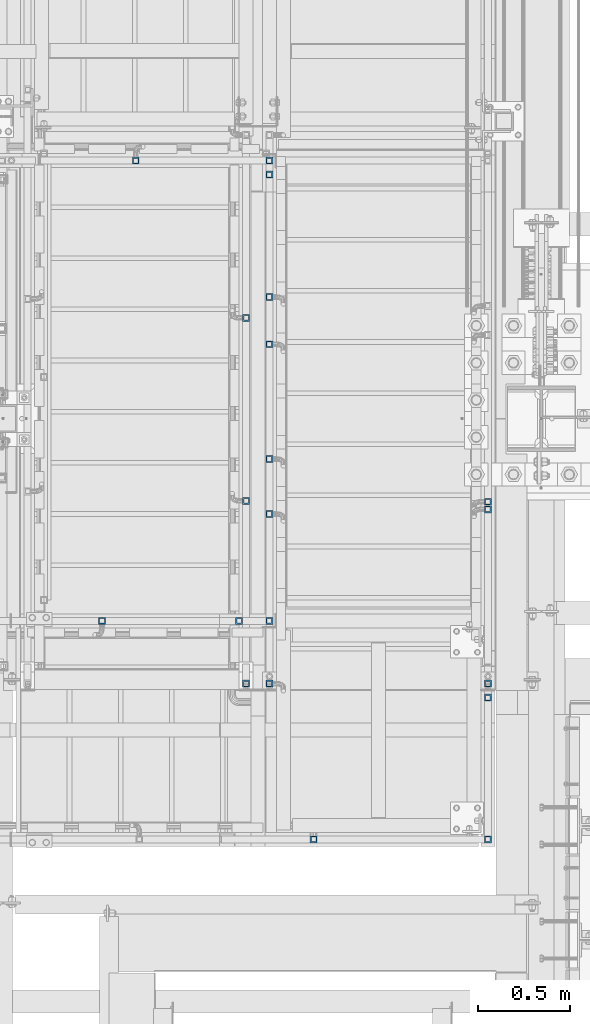
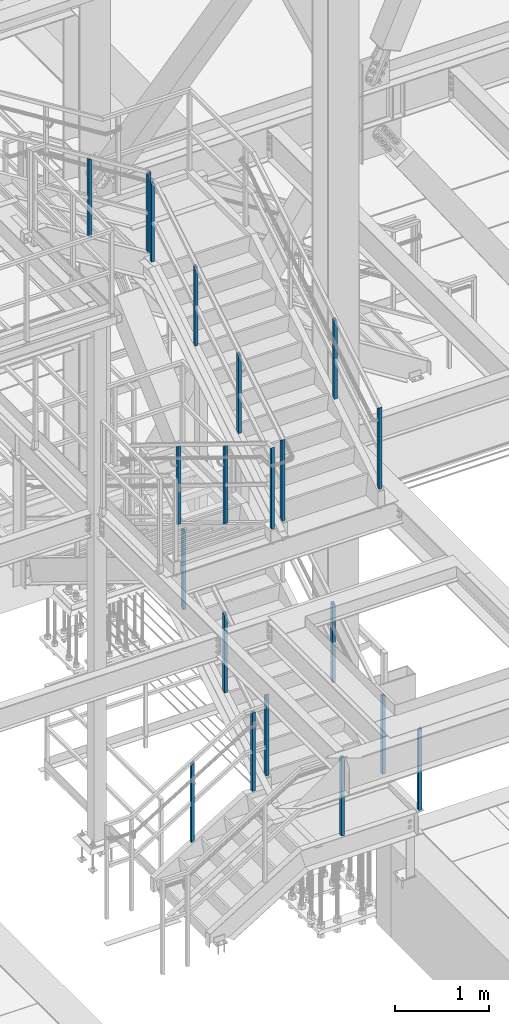
# One storey, part 1294 of 3843: 20 columns, 8 elements without a shape of their own.
"""IFC2X3 building model written with IfcOpenShell, lengths in millimetres."""

from ifc_helpers import new_model, si_unit, frame, origin_with_axes, place, context, subcontext, project, spatial, faceted_brep, material, type_object, element, aggregate, save


model = new_model("IFC2X3")

# Units and contexts
model_context = context("Model", 3, precision=1e-05, world=origin_with_axes())
body_context = subcontext(model_context, "Body", "Model", "MODEL_VIEW")
ifc_project = project(units=[si_unit("LENGTHUNIT", "METRE", prefix="MILLI"), si_unit("AREAUNIT", "SQUARE_METRE"), si_unit("VOLUMEUNIT", "CUBIC_METRE"), si_unit("MASSUNIT", "GRAM", prefix="KILO"), si_unit("TIMEUNIT", "SECOND"), si_unit("PLANEANGLEUNIT", "RADIAN"), si_unit("SOLIDANGLEUNIT", "STERADIAN"), si_unit("THERMODYNAMICTEMPERATUREUNIT", "DEGREE_CELSIUS"), si_unit("LUMINOUSINTENSITYUNIT", "LUMEN")], contexts=[model_context])

# Site, building, storey
site_placement = place(None, origin_with_axes())
site = spatial("IfcSite", under=ifc_project, at=site_placement, CompositionType="ELEMENT")
building_placement = place(site_placement, origin_with_axes())
building = spatial("IfcBuilding", under=site, at=building_placement, Name="Undefined", CompositionType="ELEMENT")
storey_placement = place(building_placement, origin_with_axes())
storey = spatial("IfcBuildingStorey", under=building, at=storey_placement, Name="Undefined", CompositionType="ELEMENT", Elevation=0.0)

# Assembly, columns
assembly_1_placement = place(storey_placement, origin_with_axes())
assembly_1 = element("IfcElementAssembly", 1, at=assembly_1_placement, inside=storey, Name="RAIL", AssemblyPlace="NOTDEFINED", PredefinedType="RIGID_FRAME")
ifc_material = material()
column_type = type_object("IfcColumnType", Name="HSS1-1/2X1-1/2X1/4", PredefinedType="NOTDEFINED")
column_1_placement = place(assembly_1_placement, frame((53714.6499999677, 21717.0000000151, 37251.6799666844), z_axis=(1.0, 0.0, 0.0), x_axis=(0.0, 0.0, 1.0)))
column_1 = element("IfcColumn", 2, at=column_1_placement, type_object=column_type, material=ifc_material, Name="POST", ObjectType="HSS1-1/2X1-1/2X1/4", context=body_context, shape_type="Brep", body=[
    faceted_brep([(-11.8918177007654, -19.0499992350015, 19.0499992350015), (11.8918177042287, -19.0499992350015, -19.0499992350015), (1026.29209956247, -19.0499999999993, -19.0499992350015), (1002.50846415752, -19.0499992350015, 19.0499992350015), (-11.8918177007654, 19.0499992350015, 19.0499992350015), (1002.50846415752, 19.0499992350015, 19.0499992350015), (11.8918177042287, 19.0499992350015, -19.0499992350015), (1026.29209956247, 19.0499992350015, -19.0499992350015), (-7.92787836672505, 12.6999993300014, 12.6999993299978), (-7.92787836672505, -12.6999993300014, 12.6999993299978), (7.92787837018841, -12.6999993300014, -12.6999993299978), (7.92787837018841, 12.6999993300014, -12.6999993299978), (1022.32816022843, 12.6999993300014, -12.6999993299978), (1006.47240349156, 12.6999993300014, 12.6999993299978), (1006.47240349156, -12.6999993300014, 12.6999993299978), (1022.32816022843, -12.6999993300014, -12.6999993299978)], [[[0, 1, 2, 3]], [[4, 0, 3, 5]], [[6, 4, 5, 7]], [[1, 0, 4, 6], [8, 9, 10, 11]], [[8, 11, 12, 13]], [[9, 8, 13, 14]], [[10, 9, 14, 15]], [[11, 10, 15, 12]], [[2, 7, 5, 3], [15, 14, 13, 12]], [[1, 6, 7, 2]]]),
])
column_2_placement = place(assembly_1_placement, frame((54444.900000001, 21717.0000000151, 36795.8269364284), z_axis=(1.0, 0.0, 0.0), x_axis=(0.0, 0.0, 1.0)))
column_2 = element("IfcColumn", 3, at=column_2_placement, type_object=column_type, material=ifc_material, Name="POST", ObjectType="HSS1-1/2X1-1/2X1/4", context=body_context, shape_type="Brep", body=[
    faceted_brep([(7.92787837018841, 12.6999993300014, -12.6999993299978), (7.92787837018841, -12.6999993300014, -12.6999993299978), (1029.81383504171, -12.6999993300014, -12.6999993299978), (1029.81383504171, 12.6999993300014, -12.6999993299978), (-7.92787836672505, -12.6999993300014, 12.6999993299978), (1043.90077281564, -12.6999993300014, 12.6999993299978), (-7.92787836672505, 12.6999993300014, 12.6999993299978), (1043.90077281564, 12.6999993300014, 12.6999993299978), (11.8918177042287, 19.0499992350015, -19.0499992350015), (-11.8918177007654, 19.0499992350015, 19.0499992350015), (1047.42250739222, 19.0499992350015, 19.0499992350015), (1026.29209956247, 19.0499992350015, -19.0499992350015), (-11.8918177007654, -19.0499992350015, 19.0499992350015), (1047.42250739222, -19.0499992350015, 19.0499992350015), (11.8918177042287, -19.0499992350015, -19.0499992350015), (1026.29209956247, -19.0499999999993, -19.0499992350015)], [[[0, 1, 2, 3]], [[1, 4, 5, 2]], [[4, 6, 7, 5]], [[6, 0, 3, 7]], [[8, 9, 10, 11]], [[9, 12, 13, 10]], [[12, 14, 15, 13]], [[14, 8, 11, 15]], [[13, 15, 11, 10], [5, 7, 3, 2]], [[14, 12, 9, 8], [6, 4, 1, 0]]]),
])
aggregate(assembly_1, [column_1, column_2])

assembly_2_placement = place(storey_placement, origin_with_axes())
assembly_2 = element("IfcElementAssembly", 4, at=assembly_2_placement, inside=storey, Name="RAIL", AssemblyPlace="NOTDEFINED", PredefinedType="RIGID_FRAME")
column_3_placement = place(assembly_2_placement, frame((54444.9, 21640.8000000047, 36694.533331298), z_axis=(0.0, -1.0, 0.0), x_axis=(0.0, 0.0, 1.0)))
column_3 = element("IfcColumn", 5, at=column_3_placement, type_object=column_type, material=ifc_material, Name="POST", ObjectType="HSS1-1/2X1-1/2X1/4", context=body_context, shape_type="Brep", body=[
    faceted_brep([(1079.49999933128, -12.6999993300014, -12.6999993299978), (1079.49999933128, 12.6999993300014, -12.6999993299978), (25.4000000135893, 12.6999993300014, -12.6999993299978), (25.4000000135893, -12.6999993300014, -12.6999993299978), (1054.10000067129, -12.6999993300014, 12.6999993299978), (25.4000000135893, -12.6999993300014, 12.6999993299978), (1054.10000067129, 12.6999993300014, 12.6999993299978), (25.4000000135893, 12.6999993300014, 12.6999993299978), (1047.75000076629, 19.0499992350015, 19.0499992349942), (1085.84999923629, 19.0499992350015, -19.0499992349942), (25.4000000135893, 19.0499992350015, -19.0499992349942), (25.4000000135893, 19.0499992350015, 19.0499992349942), (1047.75000076629, -19.0499992350015, 19.0499992349942), (25.4000000135893, -19.0499992350015, 19.0499992349942), (1085.84999923629, -19.0499992350015, -19.0499992349942), (25.4000000135893, -19.0499992350015, -19.0499992349942)], [[[0, 1, 2, 3]], [[4, 0, 3, 5]], [[6, 4, 5, 7]], [[1, 6, 7, 2]], [[8, 9, 10, 11]], [[12, 8, 11, 13]], [[14, 12, 13, 15]], [[9, 14, 15, 10]], [[12, 14, 9, 8], [4, 6, 1, 0]], [[10, 15, 13, 11], [2, 7, 5, 3]]]),
])
column_4_placement = place(assembly_2_placement, frame((54444.9, 20713.7000000044, 36201.2360274213), z_axis=(0.0, -1.0, 0.0), x_axis=(0.0, 0.0, 1.0)))
column_4 = element("IfcColumn", 6, at=column_4_placement, type_object=column_type, material=ifc_material, Name="POST", ObjectType="HSS1-1/2X1-1/2X1/4", context=body_context, shape_type="Brep", body=[
    faceted_brep([(7.92787837018841, 12.6999993300014, -12.6999993299978), (7.92787837018841, -12.6999993300014, -12.6999993299978), (1022.32816022843, -12.6999993300014, -12.6999993299978), (1022.32816022843, 12.6999993300014, -12.6999993299978), (-7.92787836672505, -12.6999993300014, 12.6999993299978), (1006.47240349156, -12.6999993300014, 12.6999993299978), (-7.92787836672505, 12.6999993300014, 12.6999993299978), (1006.47240349156, 12.6999993300014, 12.6999993299978), (11.8918177042287, 19.0499992350015, -19.0499992350015), (-11.8918177007654, 19.0499992350015, 19.0499992350015), (1002.50846415752, 19.0499992350015, 19.0499992350015), (1026.29209956247, 19.0499992350015, -19.0499992350015), (-11.8918177007654, -19.0499992350015, 19.0499992350015), (1002.50846415752, -19.0499992350015, 19.0499992350015), (11.8918177042287, -19.0499992350015, -19.0499992350015), (1026.29209956247, -19.0499999999993, -19.0499992350015)], [[[0, 1, 2, 3]], [[1, 4, 5, 2]], [[4, 6, 7, 5]], [[6, 0, 3, 7]], [[8, 9, 10, 11]], [[9, 12, 13, 10]], [[12, 14, 15, 13]], [[14, 8, 11, 15]], [[15, 11, 10, 13], [2, 5, 7, 3]], [[14, 12, 9, 8], [6, 4, 1, 0]]]),
])
column_5_placement = place(assembly_2_placement, frame((54444.9, 19786.6000000041, 35622.500875992), z_axis=(0.0, -1.0, 0.0), x_axis=(0.0, 0.0, 1.0)))
column_5 = element("IfcColumn", 7, at=column_5_placement, type_object=column_type, material=ifc_material, Name="POST", ObjectType="HSS1-1/2X1-1/2X1/4", context=body_context, shape_type="Brep", body=[
    faceted_brep([(7.92787837018841, 12.6999993300014, -12.6999993299978), (7.92787837018841, -12.6999993300014, -12.6999993299978), (1022.32816022843, -12.6999993300014, -12.6999993299978), (1022.32816022843, 12.6999993300014, -12.6999993299978), (-7.92787836672505, -12.6999993300014, 12.6999993299978), (1006.47240349156, -12.6999993300014, 12.6999993299978), (-7.92787836672505, 12.6999993300014, 12.6999993299978), (1006.47240349156, 12.6999993300014, 12.6999993299978), (11.8918177042287, 19.0499992350015, -19.0499992350015), (-11.8918177007654, 19.0499992350015, 19.0499992350015), (1002.50846415752, 19.0499992350015, 19.0499992350015), (1026.29209956247, 19.0499992350015, -19.0499992350015), (-11.8918177007654, -19.0499992350015, 19.0499992350015), (1002.50846415752, -19.0499992350015, 19.0499992350015), (11.8918177042287, -19.0499992350015, -19.0499992350015), (1026.29209956247, -19.0499999999993, -19.0499992350015)], [[[0, 1, 2, 3]], [[1, 4, 5, 2]], [[4, 6, 7, 5]], [[6, 0, 3, 7]], [[8, 9, 10, 11]], [[9, 12, 13, 10]], [[12, 14, 15, 13]], [[14, 8, 11, 15]], [[15, 11, 10, 13], [2, 5, 7, 3]], [[14, 12, 9, 8], [6, 4, 1, 0]]]),
])
column_6_placement = place(assembly_2_placement, frame((54444.9, 18859.5000000038, 35043.7657245628), z_axis=(0.0, -1.0, 0.0), x_axis=(0.0, 0.0, 1.0)))
column_6 = element("IfcColumn", 8, at=column_6_placement, type_object=column_type, material=ifc_material, Name="POST", ObjectType="HSS1-1/2X1-1/2X1/4", context=body_context, shape_type="Brep", body=[
    faceted_brep([(7.92787837018841, 12.6999993300014, -12.6999993299978), (7.92787837018841, -12.6999993300014, -12.6999993299978), (1029.81383504171, -12.6999993300014, -12.6999993299978), (1029.81383504171, 12.6999993300014, -12.6999993299978), (-7.92787836672505, -12.6999993300014, 12.6999993299978), (1043.90077281564, -12.6999993300014, 12.6999993299978), (-7.92787836672505, 12.6999993300014, 12.6999993299978), (1043.90077281564, 12.6999993300014, 12.6999993299978), (11.8918177042287, 19.0499992350015, -19.0499992350015), (-11.8918177007654, 19.0499992350015, 19.0499992350015), (1047.42250739222, 19.0499992350015, 19.0499992350015), (1026.29209956247, 19.0499992350015, -19.0499992350015), (-11.8918177007654, -19.0499992350015, 19.0499992350015), (1047.42250739222, -19.0499992350015, 19.0499992350015), (11.8918177042287, -19.0499992350015, -19.0499992350015), (1026.29209956247, -19.0499999999993, -19.0499992350015)], [[[0, 1, 2, 3]], [[1, 4, 5, 2]], [[4, 6, 7, 5]], [[6, 0, 3, 7]], [[8, 9, 10, 11]], [[9, 12, 13, 10]], [[12, 14, 15, 13]], [[14, 8, 11, 15]], [[13, 15, 11, 10], [5, 7, 3, 2]], [[14, 12, 9, 8], [6, 4, 1, 0]]]),
])
aggregate(assembly_2, [column_3, column_4, column_5, column_6])

assembly_3_placement = place(storey_placement, origin_with_axes())
assembly_3 = element("IfcElementAssembly", 9, at=assembly_3_placement, inside=storey, Name="RAIL", AssemblyPlace="NOTDEFINED", PredefinedType="RIGID_FRAME")
column_7_placement = place(assembly_3_placement, frame((55638.7, 19812.0000000041, 35638.3566335654), z_axis=(0.0, -1.0, 0.0), x_axis=(0.0, 0.0, 1.0)))
column_7 = element("IfcColumn", 10, at=column_7_placement, type_object=column_type, material=ifc_material, Name="POST", ObjectType="HSS1-1/2X1-1/2X1/4", context=body_context, shape_type="Brep", body=[
    faceted_brep([(7.92787837018841, 12.6999993300014, -12.6999993299978), (7.92787837018841, -12.6999993300014, -12.6999993299978), (1022.32816022843, -12.6999993300014, -12.6999993299978), (1022.32816022843, 12.6999993300014, -12.6999993299978), (-7.92787836672505, -12.6999993300014, 12.6999993299978), (1006.47240349156, -12.6999993300014, 12.6999993299978), (-7.92787836672505, 12.6999993300014, 12.6999993299978), (1006.47240349156, 12.6999993300014, 12.6999993299978), (11.8918177042287, 19.0499992350015, -19.0499992350015), (-11.8918177007654, 19.0499992350015, 19.0499992350015), (1002.50846415752, 19.0499992350015, 19.0499992350015), (1026.29209956247, 19.0499992350015, -19.0499992350015), (-11.8918177007654, -19.0499992350015, 19.0499992350015), (1002.50846415752, -19.0499992350015, 19.0499992350015), (11.8918177042287, -19.0499992350015, -19.0499992350015), (1026.29209956247, -19.0499999999993, -19.0499992350015)], [[[0, 1, 2, 3]], [[1, 4, 5, 2]], [[4, 6, 7, 5]], [[6, 0, 3, 7]], [[8, 9, 10, 11]], [[9, 12, 13, 10]], [[12, 14, 15, 13]], [[14, 8, 11, 15]], [[15, 11, 10, 13], [2, 5, 7, 3]], [[14, 12, 9, 8], [6, 4, 1, 0]]]),
])
column_8_placement = place(assembly_3_placement, frame((55638.7, 18859.5000000038, 35043.7657245628), z_axis=(0.0, -1.0, 0.0), x_axis=(0.0, 0.0, 1.0)))
column_8 = element("IfcColumn", 11, at=column_8_placement, type_object=column_type, material=ifc_material, Name="POST", ObjectType="HSS1-1/2X1-1/2X1/4", context=body_context, shape_type="Brep", body=[
    faceted_brep([(7.92787837018841, 12.6999993300014, -12.6999993299978), (7.92787837018841, -12.6999993300014, -12.6999993299978), (1029.81383504171, -12.6999993300014, -12.6999993299978), (1029.81383504171, 12.6999993300014, -12.6999993299978), (-7.92787836672505, -12.6999993300014, 12.6999993299978), (1043.90077281564, -12.6999993300014, 12.6999993299978), (-7.92787836672505, 12.6999993300014, 12.6999993299978), (1043.90077281564, 12.6999993300014, 12.6999993299978), (11.8918177042287, 19.0499992350015, -19.0499992350015), (-11.8918177007654, 19.0499992350015, 19.0499992350015), (1047.42250739222, 19.0499992350015, 19.0499992350015), (1026.29209956247, 19.0499992350015, -19.0499992350015), (-11.8918177007654, -19.0499992350015, 19.0499992350015), (1047.42250739222, -19.0499992350015, 19.0499992350015), (11.8918177042287, -19.0499992350015, -19.0499992350015), (1026.29209956247, -19.0499999999993, -19.0499992350015)], [[[0, 1, 2, 3]], [[1, 4, 5, 2]], [[4, 6, 7, 5]], [[6, 0, 3, 7]], [[8, 9, 10, 11]], [[9, 12, 13, 10]], [[12, 14, 15, 13]], [[14, 8, 11, 15]], [[13, 15, 11, 10], [5, 7, 3, 2]], [[14, 12, 9, 8], [6, 4, 1, 0]]]),
])
aggregate(assembly_3, [column_7, column_8])

assembly_4_placement = place(storey_placement, origin_with_axes())
assembly_4 = element("IfcElementAssembly", 12, at=assembly_4_placement, inside=storey, Name="RAIL", AssemblyPlace="NOTDEFINED", PredefinedType="RIGID_FRAME")
column_9_placement = place(assembly_4_placement, frame((54317.9, 18859.4999999931, 34950.3999969276), z_axis=(0.0, 1.0, 0.0), x_axis=(0.0, 0.0, 1.0)))
column_9 = element("IfcColumn", 13, at=column_9_placement, type_object=column_type, material=ifc_material, Name="POST", ObjectType="HSS1-1/2X1-1/2X1/4", context=body_context, shape_type="Brep", body=[
    faceted_brep([(1047.75000076629, -19.0499992350015, 19.0499992349942), (1047.75000076629, 19.0499992350015, 19.0499992349942), (25.4000000135893, 19.0499992350015, 19.0499992349942), (25.4000000135893, -19.0499992350015, 19.0499992349942), (1085.84999923629, -19.0499992350015, -19.0499992349942), (25.4000000135893, -19.0499992350015, -19.0499992349942), (1085.84999923629, 19.0499992350015, -19.0499992349942), (25.4000000135893, 19.0499992350015, -19.0499992349942), (1054.10000067129, -12.6999993300014, 12.6999993299978), (1054.10000067129, 12.6999993300014, 12.6999993299978), (1079.49999933128, 12.6999993300014, -12.6999993299978), (1079.49999933128, -12.6999993300014, -12.6999993299978), (25.4000000135893, -12.6999993300014, 12.6999993299978), (25.4000000135893, 12.6999993300014, 12.6999993299978), (25.4000000135893, 12.6999993300014, -12.6999993299978), (25.4000000135893, -12.6999993300014, -12.6999993299978)], [[[0, 1, 2, 3]], [[4, 0, 3, 5]], [[6, 4, 5, 7]], [[1, 6, 7, 2]], [[0, 4, 6, 1], [8, 9, 10, 11]], [[9, 8, 12, 13]], [[10, 9, 13, 14]], [[11, 10, 14, 15]], [[8, 11, 15, 12]], [[7, 5, 3, 2], [14, 13, 12, 15]]]),
])
column_10_placement = place(assembly_4_placement, frame((54317.9, 19858.5666666594, 34427.9369837332), z_axis=(0.0, 1.0, 0.0), x_axis=(0.0, 0.0, 1.0)))
column_10 = element("IfcColumn", 14, at=column_10_placement, type_object=column_type, material=ifc_material, Name="POST", ObjectType="HSS1-1/2X1-1/2X1/4", context=body_context, shape_type="Brep", body=[
    faceted_brep([(7.81538423420716, 12.6999993299978, -12.6999993300014), (7.81538423420716, -12.6999993299978, -12.6999993300014), (1022.42309164321, -12.6999993299978, -12.6999993300014), (1022.42309164321, 12.6999993299978, -12.6999993300014), (-7.81538414671377, -12.6999993299978, 12.6999993300014), (1006.79232326229, -12.6999993299978, 12.6999993300014), (-7.81538414671377, 12.6999993299978, 12.6999993300014), (1006.79232326229, 12.6999993299978, 12.6999993300014), (11.7230764771302, 19.0499992350015, -19.0499992350015), (-11.7230763896368, 19.0499992350015, 19.0499992350015), (1002.88463101937, 19.0499992350015, 19.0499992350015), (1026.33078388613, 19.0499992350015, -19.0499992350015), (-11.7230763896368, -19.0499992350015, 19.0499992350015), (1002.88463101937, -19.0499992350015, 19.0499992350015), (11.7230764771302, -19.0499992350015, -19.0499992350015), (1026.33078388613, -19.0499992350015, -19.0499992350015)], [[[0, 1, 2, 3]], [[1, 4, 5, 2]], [[4, 6, 7, 5]], [[6, 0, 3, 7]], [[8, 9, 10, 11]], [[9, 12, 13, 10]], [[12, 14, 15, 13]], [[14, 8, 11, 15]], [[13, 15, 11, 10], [5, 7, 3, 2]], [[14, 12, 9, 8], [6, 4, 1, 0]]]),
])
column_11_placement = place(assembly_4_placement, frame((54317.9, 20857.6333333263, 33813.1267283255), z_axis=(0.0, 1.0, 0.0), x_axis=(0.0, 0.0, 1.0)))
column_11 = element("IfcColumn", 15, at=column_11_placement, type_object=column_type, material=ifc_material, Name="POST", ObjectType="HSS1-1/2X1-1/2X1/4", context=body_context, shape_type="Brep", body=[
    faceted_brep([(7.81538423420716, 12.6999993299978, -12.6999993300014), (7.81538423420716, -12.6999993299978, -12.6999993300014), (1022.42309164321, -12.6999993299978, -12.6999993300014), (1022.42309164321, 12.6999993299978, -12.6999993300014), (-7.81538414671377, -12.6999993299978, 12.6999993300014), (1006.79232326229, -12.6999993299978, 12.6999993300014), (-7.81538414671377, 12.6999993299978, 12.6999993300014), (1006.79232326229, 12.6999993299978, 12.6999993300014), (11.7230764771302, 19.0499992350015, -19.0499992350015), (-11.7230763896368, 19.0499992350015, 19.0499992350015), (1002.88463101937, 19.0499992350015, 19.0499992350015), (1026.33078388613, 19.0499992350015, -19.0499992350015), (-11.7230763896368, -19.0499992350015, 19.0499992350015), (1002.88463101937, -19.0499992350015, 19.0499992350015), (11.7230764771302, -19.0499992350015, -19.0499992350015), (1026.33078388613, -19.0499992350015, -19.0499992350015)], [[[0, 1, 2, 3]], [[1, 4, 5, 2]], [[4, 6, 7, 5]], [[6, 0, 3, 7]], [[8, 9, 10, 11]], [[9, 12, 13, 10]], [[12, 14, 15, 13]], [[14, 8, 11, 15]], [[13, 15, 11, 10], [5, 7, 3, 2]], [[14, 12, 9, 8], [6, 4, 1, 0]]]),
])
aggregate(assembly_4, [column_9, column_10, column_11])

assembly_5_placement = place(storey_placement, origin_with_axes())
assembly_5 = element("IfcElementAssembly", 16, at=assembly_5_placement, inside=storey, Name="RAIL", AssemblyPlace="NOTDEFINED", PredefinedType="RIGID_FRAME")
column_12_placement = place(assembly_5_placement, frame((55638.6999999959, 18008.6000001452, 31365.0923070972), z_axis=(-1.0, 0.0, 0.0), x_axis=(0.0, 0.0, 1.0)))
column_12 = element("IfcColumn", 17, at=column_12_placement, type_object=column_type, material=ifc_material, Name="POST", ObjectType="HSS1-1/2X1-1/2X1/4", context=body_context, shape_type="Brep", body=[
    faceted_brep([(0.0, 12.6999993299978, -12.6999993300014), (0.0, -12.6999993299978, -12.6999993300014), (1054.10000067001, -12.6999993300014, -12.6999993299978), (1054.10000067001, 12.6999993300014, -12.6999993299978), (0.0, -12.6999993299978, 12.6999993300014), (1028.70000067002, -12.6999993299978, 12.6999993299978), (0.0, 12.6999993299978, 12.6999993300014), (1028.70000067002, 12.6999993299978, 12.6999993299978), (0.0, 19.0500000000029, -19.0499999999993), (0.0, 19.0499992350015, 19.0499992350015), (1022.35000076501, 19.0499992350015, 19.0499992350015), (1060.44999923502, 19.0499992350015, -19.0499992350015), (0.0, -19.0499992350015, 19.0499992350015), (1022.35000076501, -19.0499992350015, 19.0499992350015), (0.0, -19.0499992350015, -19.0499992350015), (1060.44999923502, -19.0499992350015, -19.0499992350015)], [[[0, 1, 2, 3]], [[1, 4, 5, 2]], [[4, 6, 7, 5]], [[6, 0, 3, 7]], [[8, 9, 10, 11]], [[9, 12, 13, 10]], [[12, 14, 15, 13]], [[14, 8, 11, 15]], [[13, 15, 11, 10], [5, 7, 3, 2]], [[14, 12, 9, 8], [6, 4, 1, 0]]]),
])
column_13_placement = place(assembly_5_placement, frame((54686.1999999943, 18008.6000001452, 31365.0923070972), z_axis=(-1.0, 0.0, 0.0), x_axis=(0.0, 0.0, 1.0)))
column_13 = element("IfcColumn", 18, at=column_13_placement, type_object=column_type, material=ifc_material, Name="POST", ObjectType="HSS1-1/2X1-1/2X1/4", context=body_context, shape_type="Brep", body=[
    faceted_brep([(1022.35000076501, -19.0499992350015, 19.0499992350015), (1022.35000076501, -19.0499992350015, -19.0499992350015), (1022.35000076501, 19.0499992350015, -19.0499992350015), (1022.35000076501, 19.0499992350015, 19.0499992350015), (1022.35000076501, -12.6999993299978, 12.6999993300014), (1022.35000076501, 12.6999993299978, 12.6999993300014), (1022.35000076501, 12.6999993299978, -12.6999993300014), (1022.35000076501, -12.6999993299978, -12.6999993300014), (0.0, 19.0499992350015, 19.0499992350015), (0.0, -19.0499992350015, 19.0499992350015), (0.0, -19.0499992350015, -19.0499992350015), (0.0, 19.0500000000029, -19.0499999999993), (0.0, 12.6999993299978, 12.6999993300014), (0.0, -12.6999993299978, 12.6999993300014), (0.0, -12.6999993299978, -12.6999993300014), (0.0, 12.6999993299978, -12.6999993300014)], [[[0, 1, 2, 3], [4, 5, 6, 7]], [[8, 9, 0, 3]], [[10, 11, 2, 1]], [[9, 10, 1, 0]], [[11, 8, 3, 2]], [[10, 9, 8, 11], [12, 13, 14, 15]], [[14, 13, 4, 7]], [[15, 14, 7, 6]], [[12, 15, 6, 5]], [[13, 12, 5, 4]]]),
])
aggregate(assembly_5, [column_12, column_13])

assembly_6_placement = place(storey_placement, origin_with_axes())
assembly_6 = element("IfcElementAssembly", 19, at=assembly_6_placement, inside=storey, Name="RAIL", AssemblyPlace="NOTDEFINED", PredefinedType="RIGID_FRAME")
column_14_placement = place(assembly_6_placement, frame((54444.9, 20971.9333333355, 32606.9523709943), z_axis=(0.0, -1.0, 0.0), x_axis=(0.0, 0.0, 1.0)))
column_14 = element("IfcColumn", 20, at=column_14_placement, type_object=column_type, material=ifc_material, Name="POST", ObjectType="HSS1-1/2X1-1/2X1/4", context=body_context, shape_type="Brep", body=[
    faceted_brep([(7.81538423420716, 12.6999993299978, -12.6999993300014), (7.81538423420716, -12.6999993299978, -12.6999993300014), (1022.42309164321, -12.6999993299978, -12.6999993300014), (1022.42309164321, 12.6999993299978, -12.6999993300014), (-7.81538414671377, -12.6999993299978, 12.6999993300014), (1006.79232326229, -12.6999993299978, 12.6999993300014), (-7.81538414671377, 12.6999993299978, 12.6999993300014), (1006.79232326229, 12.6999993299978, 12.6999993300014), (11.7230764771302, 19.0499992350015, -19.0499992350015), (-11.7230763896368, 19.0499992350015, 19.0499992350015), (1002.88463101937, 19.0499992350015, 19.0499992350015), (1026.33078388613, 19.0499992350015, -19.0499992350015), (-11.7230763896368, -19.0499992350015, 19.0499992350015), (1002.88463101937, -19.0499992350015, 19.0499992350015), (11.7230764771302, -19.0499992350015, -19.0499992350015), (1026.33078388613, -19.0499992350015, -19.0499992350015)], [[[0, 1, 2, 3]], [[1, 4, 5, 2]], [[4, 6, 7, 5]], [[6, 0, 3, 7]], [[8, 9, 10, 11]], [[9, 12, 13, 10]], [[12, 14, 15, 13]], [[14, 8, 11, 15]], [[13, 15, 11, 10], [5, 7, 3, 2]], [[14, 12, 9, 8], [6, 4, 1, 0]]]),
])
column_15_placement = place(assembly_6_placement, frame((54444.9, 20087.1666666677, 32062.4805770009), z_axis=(0.0, -1.0, 0.0), x_axis=(0.0, 0.0, 1.0)))
column_15 = element("IfcColumn", 21, at=column_15_placement, type_object=column_type, material=ifc_material, Name="POST", ObjectType="HSS1-1/2X1-1/2X1/4", context=body_context, shape_type="Brep", body=[
    faceted_brep([(7.81538423420716, 12.6999993299978, -12.6999993300014), (7.81538423420716, -12.6999993299978, -12.6999993300014), (1022.42309164321, -12.6999993299978, -12.6999993300014), (1022.42309164321, 12.6999993299978, -12.6999993300014), (-7.81538414671377, -12.6999993299978, 12.6999993300014), (1006.79232326229, -12.6999993299978, 12.6999993300014), (-7.81538414671377, 12.6999993299978, 12.6999993300014), (1006.79232326229, 12.6999993299978, 12.6999993300014), (11.7230764771302, 19.0499992350015, -19.0499992350015), (-11.7230763896368, 19.0499992350015, 19.0499992350015), (1002.88463101937, 19.0499992350015, 19.0499992350015), (1026.33078388613, 19.0499992350015, -19.0499992350015), (-11.7230763896368, -19.0499992350015, 19.0499992350015), (1002.88463101937, -19.0499992350015, 19.0499992350015), (11.7230764771302, -19.0499992350015, -19.0499992350015), (1026.33078388613, -19.0499992350015, -19.0499992350015)], [[[0, 1, 2, 3]], [[1, 4, 5, 2]], [[4, 6, 7, 5]], [[6, 0, 3, 7]], [[8, 9, 10, 11]], [[9, 12, 13, 10]], [[12, 14, 15, 13]], [[14, 8, 11, 15]], [[13, 15, 11, 10], [5, 7, 3, 2]], [[14, 12, 9, 8], [6, 4, 1, 0]]]),
])
column_16_placement = place(assembly_6_placement, frame((54444.9, 19202.3999999999, 31518.0087830075), z_axis=(0.0, -1.0, 0.0), x_axis=(0.0, 0.0, 1.0)))
column_16 = element("IfcColumn", 22, at=column_16_placement, type_object=column_type, material=ifc_material, Name="POST", ObjectType="HSS1-1/2X1-1/2X1/4", context=body_context, shape_type="Brep", body=[
    faceted_brep([(7.81538423420716, 12.6999993299978, -12.6999993300014), (7.81538423420716, -12.6999993299978, -12.6999993300014), (1029.87913425495, -12.6999993299978, -12.6999993300014), (1029.87913425495, 12.6999993299978, -12.6999993300014), (-7.81538414671377, -12.6999993299978, 12.6999993300014), (1044.07253145806, -12.6999993299978, 12.6999993300014), (-7.81538414671377, 12.6999993299978, 12.6999993300014), (1044.07253145806, 12.6999993299978, 12.6999993300014), (11.7230764771302, 19.0499992350015, -19.0499992350015), (-11.7230763896368, 19.0499992350015, 19.0499992350015), (1047.62088089295, 19.0499992350015, 19.0499992350015), (1026.33078388613, 19.0499992350015, -19.0499992350015), (-11.7230763896368, -19.0499992350015, 19.0499992350015), (1047.62088089295, -19.0499992350015, 19.0499992350015), (11.7230764771302, -19.0499992350015, -19.0499992350015), (1026.33078388613, -19.0499992350015, -19.0499992350015)], [[[0, 1, 2, 3]], [[1, 4, 5, 2]], [[4, 6, 7, 5]], [[6, 0, 3, 7]], [[8, 9, 10, 11]], [[9, 12, 13, 10]], [[12, 14, 15, 13]], [[14, 8, 11, 15]], [[13, 15, 11, 10], [5, 7, 3, 2]], [[14, 12, 9, 8], [6, 4, 1, 0]]]),
])
aggregate(assembly_6, [column_14, column_15, column_16])

assembly_7_placement = place(storey_placement, origin_with_axes())
assembly_7 = element("IfcElementAssembly", 23, at=assembly_7_placement, inside=storey, Name="RAIL", AssemblyPlace="NOTDEFINED", PredefinedType="RIGID_FRAME")
column_17_placement = place(assembly_7_placement, frame((55638.7, 19853.2750000007, 31918.5472438998), z_axis=(0.0, -1.0, 0.0), x_axis=(0.0, 0.0, 1.0)))
column_17 = element("IfcColumn", 24, at=column_17_placement, type_object=column_type, material=ifc_material, Name="POST", ObjectType="HSS1-1/2X1-1/2X1/4", context=body_context, shape_type="Brep", body=[
    faceted_brep([(7.81538423420716, 12.6999993299978, -12.6999993300014), (7.81538423420716, -12.6999993299978, -12.6999993300014), (1022.42309164321, -12.6999993299978, -12.6999993300014), (1022.42309164321, 12.6999993299978, -12.6999993300014), (-7.81538414671377, -12.6999993299978, 12.6999993300014), (1006.79232326229, -12.6999993299978, 12.6999993300014), (-7.81538414671377, 12.6999993299978, 12.6999993300014), (1006.79232326229, 12.6999993299978, 12.6999993300014), (11.7230764771302, 19.0499992350015, -19.0499992350015), (-11.7230763896368, 19.0499992350015, 19.0499992350015), (1002.88463101937, 19.0499992350015, 19.0499992350015), (1026.33078388613, 19.0499992350015, -19.0499992350015), (-11.7230763896368, -19.0499992350015, 19.0499992350015), (1002.88463101937, -19.0499992350015, 19.0499992350015), (11.7230764771302, -19.0499992350015, -19.0499992350015), (1026.33078388613, -19.0499992350015, -19.0499992350015)], [[[0, 1, 2, 3]], [[1, 4, 5, 2]], [[4, 6, 7, 5]], [[6, 0, 3, 7]], [[8, 9, 10, 11]], [[9, 12, 13, 10]], [[12, 14, 15, 13]], [[14, 8, 11, 15]], [[13, 15, 11, 10], [5, 7, 3, 2]], [[14, 12, 9, 8], [6, 4, 1, 0]]]),
])
column_18_placement = place(assembly_7_placement, frame((55638.7, 18783.2999999999, 31339.6923070975), z_axis=(0.0, -1.0, 0.0), x_axis=(0.0, 0.0, 1.0)))
column_18 = element("IfcColumn", 25, at=column_18_placement, type_object=column_type, material=ifc_material, Name="POST", ObjectType="HSS1-1/2X1-1/2X1/4", context=body_context, shape_type="Brep", body=[
    faceted_brep([(1047.75000076629, -19.0499992350015, 19.0499992349942), (1047.75000076629, 19.0499992350015, 19.0499992349942), (25.4000000135893, 19.0499992350015, 19.0499992349942), (25.4000000135893, -19.0499992350015, 19.0499992349942), (1047.750000765, -19.0499992350015, -19.0499992350015), (25.4000000135893, -19.0499992350015, -19.0499992349942), (1047.750000765, 19.0499992350015, -19.0499992350015), (25.4000000135893, 19.0499992350015, -19.0499992349942), (1047.75000076497, -12.6999993300014, 12.6999993299978), (1047.75000076497, 12.6999993300014, 12.6999993299978), (1047.75000076497, 12.6999993300014, -12.6999993299978), (1047.75000076497, -12.6999993300014, -12.6999993299978), (25.4000000135893, -12.6999993300014, 12.6999993299978), (25.4000000135893, 12.6999993300014, 12.6999993299978), (25.4000000135893, 12.6999993300014, -12.6999993299978), (25.4000000135893, -12.6999993300014, -12.6999993299978)], [[[0, 1, 2, 3]], [[4, 0, 3, 5]], [[6, 4, 5, 7]], [[1, 6, 7, 2]], [[0, 4, 6, 1], [8, 9, 10, 11]], [[9, 8, 12, 13]], [[10, 9, 13, 14]], [[11, 10, 14, 15]], [[8, 11, 15, 12]], [[7, 5, 3, 2], [14, 13, 12, 15]]]),
])
aggregate(assembly_7, [column_17, column_18])

assembly_8_placement = place(storey_placement, origin_with_axes())
assembly_8 = element("IfcElementAssembly", 26, at=assembly_8_placement, inside=storey, Name="RAIL", AssemblyPlace="NOTDEFINED", PredefinedType="RIGID_FRAME")
column_19_placement = place(assembly_8_placement, frame((54279.7999999953, 19202.4000001452, 31365.0923070972), z_axis=(-1.0, 0.0, 0.0), x_axis=(0.0, 0.0, 1.0)))
column_19 = element("IfcColumn", 27, at=column_19_placement, type_object=column_type, material=ifc_material, Name="POST", ObjectType="HSS1-1/2X1-1/2X1/4", context=body_context, shape_type="Brep", body=[
    faceted_brep([(1022.35000076501, -19.0499992350015, 19.0499992350015), (1022.35000076501, -19.0499992350015, -19.0499992350015), (1022.35000076501, 19.0499992350015, -19.0499992350015), (1022.35000076501, 19.0499992350015, 19.0499992350015), (1022.35000076501, -12.6999993299978, 12.6999993300014), (1022.35000076501, 12.6999993299978, 12.6999993300014), (1022.35000076501, 12.6999993299978, -12.6999993300014), (1022.35000076501, -12.6999993299978, -12.6999993300014), (0.0, 19.0499992350015, 19.0499992350015), (0.0, -19.0499992350015, 19.0499992350015), (0.0, -19.0499992350015, -19.0499992350015), (0.0, 19.0500000000029, -19.0499999999993), (0.0, 12.6999993299978, 12.6999993300014), (0.0, -12.6999993299978, 12.6999993300014), (0.0, -12.6999993299978, -12.6999993300014), (0.0, 12.6999993299978, -12.6999993300014)], [[[0, 1, 2, 3], [4, 5, 6, 7]], [[8, 9, 0, 3]], [[10, 11, 2, 1]], [[9, 10, 1, 0]], [[11, 8, 3, 2]], [[10, 9, 8, 11], [12, 13, 14, 15]], [[14, 13, 4, 7]], [[15, 14, 7, 6]], [[12, 15, 6, 5]], [[13, 12, 5, 4]]]),
])
column_20_placement = place(assembly_8_placement, frame((53530.4999999928, 19202.4000001452, 30970.9318594976), z_axis=(-1.0, 0.0, 0.0), x_axis=(0.0, 0.0, 1.0)))
column_20 = element("IfcColumn", 28, at=column_20_placement, type_object=column_type, material=ifc_material, Name="POST", ObjectType="HSS1-1/2X1-1/2X1/4", context=body_context, shape_type="Brep", body=[
    faceted_brep([(7.81538423420716, 12.6999993299978, -12.6999993300014), (7.81538423420716, -12.6999993299978, -12.6999993300014), (1022.42309164321, -12.6999993299978, -12.6999993300014), (1022.42309164321, 12.6999993299978, -12.6999993300014), (-7.81538414671377, -12.6999993299978, 12.6999993300014), (1006.79232326229, -12.6999993299978, 12.6999993300014), (-7.81538414671377, 12.6999993299978, 12.6999993300014), (1006.79232326229, 12.6999993299978, 12.6999993300014), (11.7230764771302, 19.0499992350015, -19.0499992350015), (-11.7230763896368, 19.0499992350015, 19.0499992350015), (1002.88463101937, 19.0499992350015, 19.0499992350015), (1026.33078388613, 19.0499992350015, -19.0499992350015), (-11.7230763896368, -19.0499992350015, 19.0499992350015), (1002.88463101937, -19.0499992350015, 19.0499992350015), (11.7230764771302, -19.0499992350015, -19.0499992350015), (1026.33078388613, -19.0499992350015, -19.0499992350015)], [[[0, 1, 2, 3]], [[1, 4, 5, 2]], [[4, 6, 7, 5]], [[6, 0, 3, 7]], [[8, 9, 10, 11]], [[9, 12, 13, 10]], [[12, 14, 15, 13]], [[14, 8, 11, 15]], [[13, 15, 11, 10], [5, 7, 3, 2]], [[14, 12, 9, 8], [6, 4, 1, 0]]]),
])
aggregate(assembly_8, [column_19, column_20])

save(model, "model.ifc")
